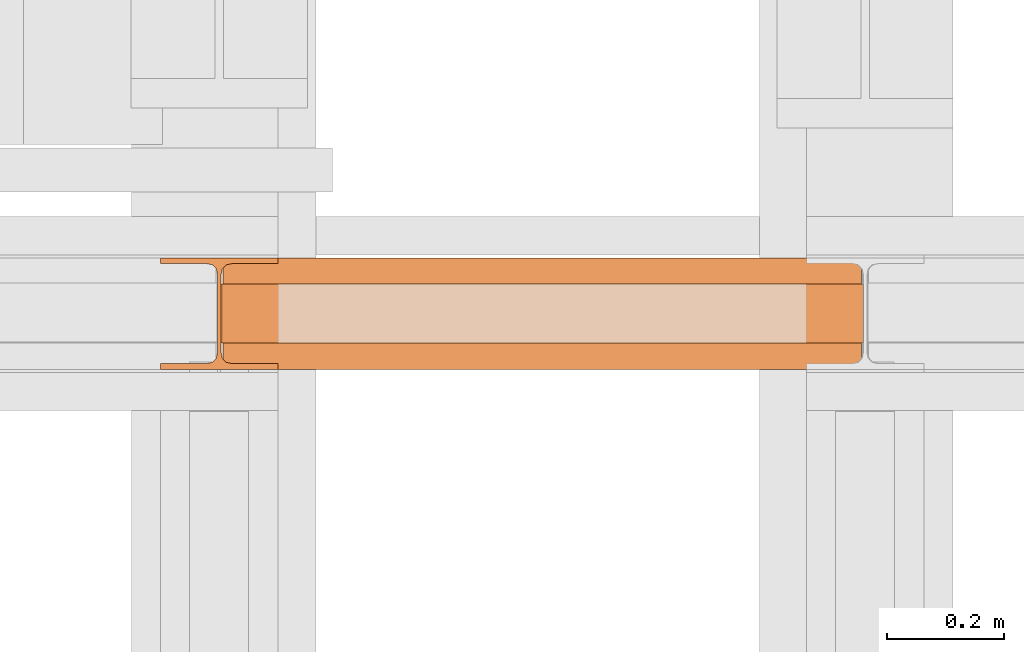
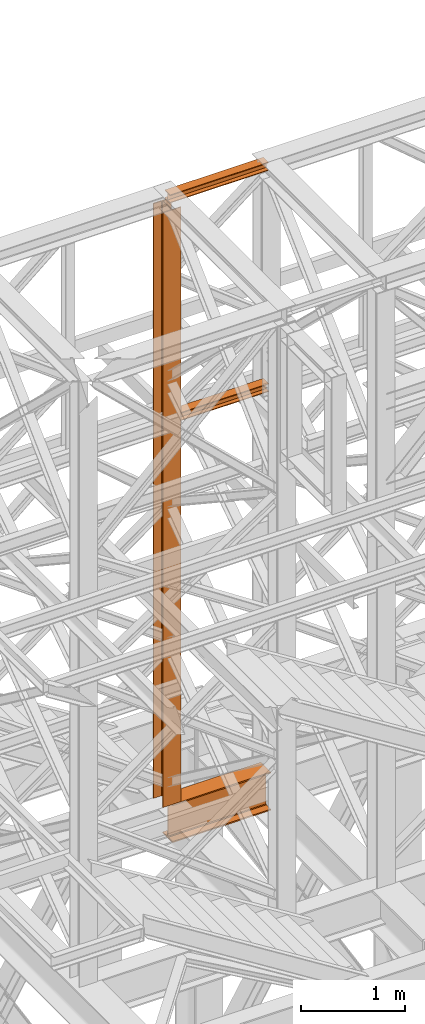
# One storey, part 104 of 208: 4 proxies.
"""IFC2X3 building model written with IfcOpenShell, lengths in millimetres."""

from ifc_helpers import new_model, entity, si_unit, converted_unit, frame, origin, origin_with_axes, place, context, subcontext, project, spatial, faceted_brep, element, save


model = new_model("IFC2X3")

# Units and contexts
model_context = context("Model", 3, precision=1e-05, world=origin())
plan_context = context("Plan", 3, precision=1e-05, world=origin())
body_context = subcontext(model_context, "Body", "Model", "MODEL_VIEW")
ifc_project = project(units=[si_unit("LENGTHUNIT", "METRE", prefix="MILLI"), converted_unit("PLANEANGLEUNIT", "DEGREE", entity("IfcPlaneAngleMeasure", 0.0174532925199433), si_unit("PLANEANGLEUNIT", "RADIAN"), dimensions=[0, 0, 0, 0, 0, 0, 0]), si_unit("AREAUNIT", "SQUARE_METRE"), si_unit("VOLUMEUNIT", "CUBIC_METRE")], contexts=[model_context, plan_context])

# Building, storey
building_placement = place(None, origin())
building = spatial("IfcBuilding", under=ifc_project, at=building_placement, CompositionType="COMPLEX")
storey_placement = place(building_placement, origin_with_axes())
storey = spatial("IfcBuildingStorey", under=building, at=storey_placement, Name="Geschoss", CompositionType="ELEMENT")

# Proxies
proxy_1_placement = place(storey_placement, frame((-1100.745031419179, -13857.57439657637, 4834.989987483023), z_axis=(0.0, 0.0, 1.0), x_axis=(1.0, 0.0, 0.0)))
element("IfcBuildingElementProxy", 1, at=proxy_1_placement, inside=storey, context=body_context, shape_type="Brep", body=[
    faceted_brep([(1088.009999895696, 0.01000000000021828, 450.0100178813937), (1088.009999895696, 190.0100125169756, 450.0100178813937), (1088.009999895696, 190.0100125169756, 435.4100240564349), (1088.009999895696, 120.7100073045494, 435.4100091552737), (1088.009999895696, 109.841562265754, 433.2347078418734), (1088.009999895696, 101.8853126263621, 425.2784563398363), (1088.009999895696, 99.71000619068764, 414.4100113010409), (1088.009999895696, 99.71000619068764, 35.60999167919181), (1088.009999895696, 101.8853126263621, 24.74154664039634), (1088.009999895696, 109.841562265754, 16.78529513835929), (1088.009999895696, 120.7100073045494, 14.60999382495902), (1088.009999895696, 190.0100125169756, 14.60999382495902), (1088.009999895696, 190.0100125169756, 0.01000000000021828), (1088.009999895696, 0.01000000000021828, 0.01000000000021828), (1088.009999895696, 0.01000000000021828, 14.60999382495902), (1088.009999895696, 69.3100052124264, 14.60999382495902), (1088.009999895696, 80.17845025122188, 16.78529513835929), (1088.009999895696, 88.13469989061377, 24.74154664039634), (1088.009999895696, 90.3100063262882, 35.60999167919181), (1088.009999895696, 90.3100063262882, 414.4100113010409), (1088.009999895696, 88.13469989061377, 425.2784563398363), (1088.009999895696, 80.17845025122188, 433.2347078418734), (1088.009999895696, 69.3100052124264, 435.4100091552737), (1088.009999895696, 0.01000000000021828, 435.4100240564349), (1088.009999895696, 190.0100125169756, 450.0100178813937), (1088.009999895696, 0.01000000000021828, 450.0100178813937), (0.009999999999990905, 0.01000000000021828, 450.0100178813937), (0.009999999999990905, 190.0100125169756, 450.0100178813937), (1088.009999895696, 190.0100125169756, 435.4100240564349), (1088.009999895696, 190.0100125169756, 450.0100178813937), (0.009999999999990905, 190.0100125169756, 450.0100178813937), (0.009999999999990905, 190.0100125169756, 435.4100240564349), (1088.009999895696, 120.7100073045494, 435.4100091552737), (1088.009999895696, 190.0100125169756, 435.4100240564349), (0.009999999999990905, 190.0100125169756, 435.4100240564349), (0.009999999999990905, 120.7100073045494, 435.4100091552737), (1088.009999895696, 109.841562265754, 433.2347078418734), (1088.009999895696, 120.7100073045494, 435.4100091552737), (0.009999999999990905, 120.7100073045494, 435.4100091552737), (0.009999999999990905, 109.841562265754, 433.2347078418734), (1088.009999895696, 101.8853126263621, 425.2784563398363), (1088.009999895696, 109.841562265754, 433.2347078418734), (0.009999999999990905, 109.841562265754, 433.2347078418734), (0.009999999999990905, 101.8853126263621, 425.2784563398363), (1088.009999895696, 99.71000619068764, 414.4100113010409), (1088.009999895696, 101.8853126263621, 425.2784563398363), (0.009999999999990905, 101.8853126263621, 425.2784563398363), (0.009999999999990905, 99.71000619068764, 414.4100113010409), (1088.009999895696, 99.71000619068764, 35.60999167919181), (1088.009999895696, 99.71000619068764, 414.4100113010409), (0.009999999999990905, 99.71000619068764, 414.4100113010409), (0.009999999999990905, 99.71000619068764, 35.60999167919181), (1088.009999895696, 101.8853126263621, 24.74154664039634), (1088.009999895696, 99.71000619068764, 35.60999167919181), (0.009999999999990905, 99.71000619068764, 35.60999167919181), (0.009999999999990905, 101.8853126263621, 24.74154664039634), (1088.009999895696, 109.841562265754, 16.78529513835929), (1088.009999895696, 101.8853126263621, 24.74154664039634), (0.009999999999990905, 101.8853126263621, 24.74154664039634), (0.009999999999990905, 109.841562265754, 16.78529513835929), (1088.009999895696, 120.7100073045494, 14.60999382495902), (1088.009999895696, 109.841562265754, 16.78529513835929), (0.009999999999990905, 109.841562265754, 16.78529513835929), (0.009999999999990905, 120.7100073045494, 14.60999382495902), (1088.009999895696, 190.0100125169756, 14.60999382495902), (1088.009999895696, 120.7100073045494, 14.60999382495902), (0.009999999999990905, 120.7100073045494, 14.60999382495902), (0.009999999999990905, 190.0100125169756, 14.60999382495902), (1088.009999895696, 190.0100125169756, 0.01000000000021828), (1088.009999895696, 190.0100125169756, 14.60999382495902), (0.009999999999990905, 190.0100125169756, 14.60999382495902), (0.009999999999990905, 190.0100125169756, 0.01000000000021828), (1088.009999895696, 0.01000000000021828, 0.01000000000021828), (1088.009999895696, 190.0100125169756, 0.01000000000021828), (0.009999999999990905, 190.0100125169756, 0.01000000000021828), (0.009999999999990905, 0.01000000000021828, 0.01000000000021828), (1088.009999895696, 0.01000000000021828, 14.60999382495902), (1088.009999895696, 0.01000000000021828, 0.01000000000021828), (0.009999999999990905, 0.01000000000021828, 0.01000000000021828), (0.009999999999990905, 0.01000000000021828, 14.60999382495902), (1088.009999895696, 69.3100052124264, 14.60999382495902), (1088.009999895696, 0.01000000000021828, 14.60999382495902), (0.009999999999990905, 0.01000000000021828, 14.60999382495902), (0.009999999999990905, 69.3100052124264, 14.60999382495902), (1088.009999895696, 80.17845025122188, 16.78529513835929), (1088.009999895696, 69.3100052124264, 14.60999382495902), (0.009999999999990905, 69.3100052124264, 14.60999382495902), (0.009999999999990905, 80.17845025122188, 16.78529513835929), (1088.009999895696, 88.13469989061377, 24.74154664039634), (1088.009999895696, 80.17845025122188, 16.78529513835929), (0.009999999999990905, 80.17845025122188, 16.78529513835929), (0.009999999999990905, 88.13469989061377, 24.74154664039634), (1088.009999895696, 90.3100063262882, 35.60999167919181), (1088.009999895696, 88.13469989061377, 24.74154664039634), (0.009999999999990905, 88.13469989061377, 24.74154664039634), (0.009999999999990905, 90.3100063262882, 35.60999167919181), (1088.009999895696, 90.3100063262882, 414.4100113010409), (1088.009999895696, 90.3100063262882, 35.60999167919181), (0.009999999999990905, 90.3100063262882, 35.60999167919181), (0.009999999999990905, 90.3100063262882, 414.4100113010409), (1088.009999895696, 88.13469989061377, 425.2784563398363), (1088.009999895696, 90.3100063262882, 414.4100113010409), (0.009999999999990905, 90.3100063262882, 414.4100113010409), (0.009999999999990905, 88.13469989061377, 425.2784563398363), (1088.009999895696, 80.17845025122188, 433.2347078418734), (1088.009999895696, 88.13469989061377, 425.2784563398363), (0.009999999999990905, 88.13469989061377, 425.2784563398363), (0.009999999999990905, 80.17845025122188, 433.2347078418734), (1088.009999895696, 69.3100052124264, 435.4100091552737), (1088.009999895696, 80.17845025122188, 433.2347078418734), (0.009999999999990905, 80.17845025122188, 433.2347078418734), (0.009999999999990905, 69.3100052124264, 435.4100091552737), (1088.009999895696, 0.01000000000021828, 435.4100240564349), (1088.009999895696, 69.3100052124264, 435.4100091552737), (0.009999999999990905, 69.3100052124264, 435.4100091552737), (0.009999999999990905, 0.01000000000021828, 435.4100240564349), (1088.009999895696, 0.01000000000021828, 450.0100178813937), (1088.009999895696, 0.01000000000021828, 435.4100240564349), (0.009999999999990905, 0.01000000000021828, 435.4100240564349), (0.009999999999990905, 0.01000000000021828, 450.0100178813937), (0.009999999999990905, 0.01000000000021828, 450.0100178813937), (0.009999999999990905, 0.01000000000021828, 435.4100240564349), (0.009999999999990905, 69.3100052124264, 435.4100091552737), (0.009999999999990905, 80.17845025122188, 433.2347078418734), (0.009999999999990905, 88.13469989061377, 425.2784563398363), (0.009999999999990905, 90.3100063262882, 414.4100113010409), (0.009999999999990905, 90.3100063262882, 35.60999167919181), (0.009999999999990905, 88.13469989061377, 24.74154664039634), (0.009999999999990905, 80.17845025122188, 16.78529513835929), (0.009999999999990905, 69.3100052124264, 14.60999382495902), (0.009999999999990905, 0.01000000000021828, 14.60999382495902), (0.009999999999990905, 0.01000000000021828, 0.01000000000021828), (0.009999999999990905, 190.0100125169756, 0.01000000000021828), (0.009999999999990905, 190.0100125169756, 14.60999382495902), (0.009999999999990905, 120.7100073045494, 14.60999382495902), (0.009999999999990905, 109.841562265754, 16.78529513835929), (0.009999999999990905, 101.8853126263621, 24.74154664039634), (0.009999999999990905, 99.71000619068764, 35.60999167919181), (0.009999999999990905, 99.71000619068764, 414.4100113010409), (0.009999999999990905, 101.8853126263621, 425.2784563398363), (0.009999999999990905, 109.841562265754, 433.2347078418734), (0.009999999999990905, 120.7100073045494, 435.4100091552737), (0.009999999999990905, 190.0100125169756, 435.4100240564349), (0.009999999999990905, 190.0100125169756, 450.0100178813937)], [[[0, 1, 2, 3, 4, 5, 6, 7, 8, 9, 10, 11, 12, 13, 14, 15, 16, 17, 18, 19, 20, 21, 22, 23]], [[24, 25, 26, 27]], [[28, 29, 30, 31]], [[32, 33, 34, 35]], [[36, 37, 38, 39]], [[40, 41, 42, 43]], [[44, 45, 46, 47]], [[48, 49, 50, 51]], [[52, 53, 54, 55]], [[56, 57, 58, 59]], [[60, 61, 62, 63]], [[64, 65, 66, 67]], [[68, 69, 70, 71]], [[72, 73, 74, 75]], [[76, 77, 78, 79]], [[80, 81, 82, 83]], [[84, 85, 86, 87]], [[88, 89, 90, 91]], [[92, 93, 94, 95]], [[96, 97, 98, 99]], [[100, 101, 102, 103]], [[104, 105, 106, 107]], [[108, 109, 110, 111]], [[112, 113, 114, 115]], [[116, 117, 118, 119]], [[120, 121, 122, 123, 124, 125, 126, 127, 128, 129, 130, 131, 132, 133, 134, 135, 136, 137, 138, 139, 140, 141, 142, 143]]], orient=[[False], [False], [False], [False], [False], [False], [False], [False], [False], [False], [False], [False], [False], [False], [False], [False], [False], [False], [False], [False], [False], [False], [False], [False], [False], [False]]),
])
proxy_2_placement = place(storey_placement, frame((-1206.745032961453, -13857.57439657637, 5284.990005364415), z_axis=(0.0, 0.0, 1.0), x_axis=(1.0, 0.0, 0.0)))
element("IfcBuildingElementProxy", 2, at=proxy_2_placement, inside=storey, context=body_context, shape_type="Brep", body=[
    faceted_brep([(0.009999999999990905, 190.0100125169756, 6965.010053329393), (200.0100029802322, 190.0100125169756, 6965.010053329393), (200.0100029802322, 180.0100146031382, 6965.010053329393), (121.2600035762787, 180.0100071525576, 6965.010053329393), (111.9441915473342, 178.1454621052744, 6965.010053329393), (105.1245498640835, 171.3258190250399, 6965.010053329393), (103.2600015571713, 162.010007927418, 6965.010053329393), (103.2600015571713, 28.00999713897727, 6965.010053329393), (105.1245498640835, 18.69418604135535, 6965.010053329393), (111.9441915473342, 11.87454296112082, 6965.010053329393), (121.2600035762787, 10.00999791383765, 6965.010053329393), (200.0100029802322, 10.00999791383765, 6965.010053329393), (200.0100029802322, 0.01000000000021828, 6965.010053329393), (0.009999999999990905, 0.01000000000021828, 6965.010053329393), (0.009999999999990905, 10.00999791383765, 6965.010053329393), (78.75999940395354, 10.00999791383765, 6965.010053329393), (88.07581143289804, 11.87454296112082, 6965.010053329393), (94.8954531161487, 18.69418604135535, 6965.010053329393), (96.76000142306088, 28.00999713897727, 6965.010053329393), (96.76000142306088, 162.010007927418, 6965.010053329393), (94.8954531161487, 171.3258190250399, 6965.010053329393), (88.07581143289804, 178.1454621052744, 6965.010053329393), (78.75999940395354, 180.0100071525576, 6965.010053329393), (0.009999999999990905, 180.0100146031382, 6965.010053329393), (200.0100029802322, 190.0100125169756, 6965.010053329393), (0.009999999999990905, 190.0100125169756, 6965.010053329393), (0.009999999999990905, 190.0100125169756, 0.01000000000112777), (200.0100029802322, 190.0100125169756, 0.01000000000112777), (200.0100029802322, 180.0100146031382, 6965.010053329393), (200.0100029802322, 190.0100125169756, 6965.010053329393), (200.0100029802322, 190.0100125169756, 0.01000000000112777), (200.0100029802322, 180.0100146031382, 0.01000000000112777), (121.2600035762787, 180.0100071525576, 6965.010053329393), (200.0100029802322, 180.0100146031382, 6965.010053329393), (200.0100029802322, 180.0100146031382, 0.01000000000112777), (121.2600035762787, 180.0100071525576, 0.01000000000112777), (111.9441915473342, 178.1454621052744, 6965.010053329393), (121.2600035762787, 180.0100071525576, 6965.010053329393), (121.2600035762787, 180.0100071525576, 0.01000000000112777), (111.9441915473342, 178.1454621052744, 0.01000000000112777), (105.1245498640835, 171.3258190250399, 6965.010053329393), (111.9441915473342, 178.1454621052744, 6965.010053329393), (111.9441915473342, 178.1454621052744, 0.01000000000112777), (105.1245498640835, 171.3258190250399, 0.01000000000112777), (103.2600015571713, 162.010007927418, 6965.010053329393), (105.1245498640835, 171.3258190250399, 6965.010053329393), (105.1245498640835, 171.3258190250399, 0.01000000000112777), (103.2600015571713, 162.010007927418, 0.01000000000112777), (103.2600015571713, 28.00999713897727, 6965.010053329393), (103.2600015571713, 162.010007927418, 6965.010053329393), (103.2600015571713, 162.010007927418, 0.01000000000112777), (103.2600015571713, 28.00999713897727, 0.01000000000112777), (105.1245498640835, 18.69418604135535, 6965.010053329393), (103.2600015571713, 28.00999713897727, 6965.010053329393), (103.2600015571713, 28.00999713897727, 0.01000000000112777), (105.1245498640835, 18.69418604135535, 0.01000000000112777), (111.9441915473342, 11.87454296112082, 6965.010053329393), (105.1245498640835, 18.69418604135535, 6965.010053329393), (105.1245498640835, 18.69418604135535, 0.01000000000112777), (111.9441915473342, 11.87454296112082, 0.01000000000112777), (121.2600035762787, 10.00999791383765, 6965.010053329393), (111.9441915473342, 11.87454296112082, 6965.010053329393), (111.9441915473342, 11.87454296112082, 0.01000000000112777), (121.2600035762787, 10.00999791383765, 0.01000000000112777), (200.0100029802322, 10.00999791383765, 6965.010053329393), (121.2600035762787, 10.00999791383765, 6965.010053329393), (121.2600035762787, 10.00999791383765, 0.01000000000112777), (200.0100029802322, 10.00999791383765, 0.01000000000112777), (200.0100029802322, 0.01000000000021828, 6965.010053329393), (200.0100029802322, 10.00999791383765, 6965.010053329393), (200.0100029802322, 10.00999791383765, 0.01000000000112777), (200.0100029802322, 0.01000000000021828, 0.01000000000112777), (0.009999999999990905, 0.01000000000021828, 6965.010053329393), (200.0100029802322, 0.01000000000021828, 6965.010053329393), (200.0100029802322, 0.01000000000021828, 0.01000000000112777), (0.009999999999990905, 0.01000000000021828, 0.01000000000112777), (0.009999999999990905, 10.00999791383765, 6965.010053329393), (0.009999999999990905, 0.01000000000021828, 6965.010053329393), (0.009999999999990905, 0.01000000000021828, 0.01000000000112777), (0.009999999999990905, 10.00999791383765, 0.01000000000112777), (78.75999940395354, 10.00999791383765, 6965.010053329393), (0.009999999999990905, 10.00999791383765, 6965.010053329393), (0.009999999999990905, 10.00999791383765, 0.01000000000112777), (78.75999940395354, 10.00999791383765, 0.01000000000112777), (88.07581143289804, 11.87454296112082, 6965.010053329393), (78.75999940395354, 10.00999791383765, 6965.010053329393), (78.75999940395354, 10.00999791383765, 0.01000000000112777), (88.07581143289804, 11.87454296112082, 0.01000000000112777), (94.8954531161487, 18.69418604135535, 6965.010053329393), (88.07581143289804, 11.87454296112082, 6965.010053329393), (88.07581143289804, 11.87454296112082, 0.01000000000112777), (94.8954531161487, 18.69418604135535, 0.01000000000112777), (96.76000142306088, 28.00999713897727, 6965.010053329393), (94.8954531161487, 18.69418604135535, 6965.010053329393), (94.8954531161487, 18.69418604135535, 0.01000000000112777), (96.76000142306088, 28.00999713897727, 0.01000000000112777), (96.76000142306088, 162.010007927418, 6965.010053329393), (96.76000142306088, 28.00999713897727, 6965.010053329393), (96.76000142306088, 28.00999713897727, 0.01000000000112777), (96.76000142306088, 162.010007927418, 0.01000000000112777), (94.8954531161487, 171.3258190250399, 6965.010053329393), (96.76000142306088, 162.010007927418, 6965.010053329393), (96.76000142306088, 162.010007927418, 0.01000000000112777), (94.8954531161487, 171.3258190250399, 0.01000000000112777), (88.07581143289804, 178.1454621052744, 6965.010053329393), (94.8954531161487, 171.3258190250399, 6965.010053329393), (94.8954531161487, 171.3258190250399, 0.01000000000112777), (88.07581143289804, 178.1454621052744, 0.01000000000112777), (78.75999940395354, 180.0100071525576, 6965.010053329393), (88.07581143289804, 178.1454621052744, 6965.010053329393), (88.07581143289804, 178.1454621052744, 0.01000000000112777), (78.75999940395354, 180.0100071525576, 0.01000000000112777), (0.009999999999990905, 180.0100146031382, 6965.010053329393), (78.75999940395354, 180.0100071525576, 6965.010053329393), (78.75999940395354, 180.0100071525576, 0.01000000000112777), (0.009999999999990905, 180.0100146031382, 0.01000000000112777), (0.009999999999990905, 190.0100125169756, 6965.010053329393), (0.009999999999990905, 180.0100146031382, 6965.010053329393), (0.009999999999990905, 180.0100146031382, 0.01000000000112777), (0.009999999999990905, 190.0100125169756, 0.01000000000112777), (0.009999999999990905, 190.0100125169756, 0.01000000000112777), (0.009999999999990905, 180.0100146031382, 0.01000000000112777), (78.75999940395354, 180.0100071525576, 0.01000000000112777), (88.07581143289804, 178.1454621052744, 0.01000000000112777), (94.8954531161487, 171.3258190250399, 0.01000000000112777), (96.76000142306088, 162.010007927418, 0.01000000000112777), (96.76000142306088, 28.00999713897727, 0.01000000000112777), (94.8954531161487, 18.69418604135535, 0.01000000000112777), (88.07581143289804, 11.87454296112082, 0.01000000000112777), (78.75999940395354, 10.00999791383765, 0.01000000000112777), (0.009999999999990905, 10.00999791383765, 0.01000000000112777), (0.009999999999990905, 0.01000000000021828, 0.01000000000112777), (200.0100029802322, 0.01000000000021828, 0.01000000000112777), (200.0100029802322, 10.00999791383765, 0.01000000000112777), (121.2600035762787, 10.00999791383765, 0.01000000000112777), (111.9441915473342, 11.87454296112082, 0.01000000000112777), (105.1245498640835, 18.69418604135535, 0.01000000000112777), (103.2600015571713, 28.00999713897727, 0.01000000000112777), (103.2600015571713, 162.010007927418, 0.01000000000112777), (105.1245498640835, 171.3258190250399, 0.01000000000112777), (111.9441915473342, 178.1454621052744, 0.01000000000112777), (121.2600035762787, 180.0100071525576, 0.01000000000112777), (200.0100029802322, 180.0100146031382, 0.01000000000112777), (200.0100029802322, 190.0100125169756, 0.01000000000112777)], [[[0, 1, 2, 3, 4, 5, 6, 7, 8, 9, 10, 11, 12, 13, 14, 15, 16, 17, 18, 19, 20, 21, 22, 23]], [[24, 25, 26, 27]], [[28, 29, 30, 31]], [[32, 33, 34, 35]], [[36, 37, 38, 39]], [[40, 41, 42, 43]], [[44, 45, 46, 47]], [[48, 49, 50, 51]], [[52, 53, 54, 55]], [[56, 57, 58, 59]], [[60, 61, 62, 63]], [[64, 65, 66, 67]], [[68, 69, 70, 71]], [[72, 73, 74, 75]], [[76, 77, 78, 79]], [[80, 81, 82, 83]], [[84, 85, 86, 87]], [[88, 89, 90, 91]], [[92, 93, 94, 95]], [[96, 97, 98, 99]], [[100, 101, 102, 103]], [[104, 105, 106, 107]], [[108, 109, 110, 111]], [[112, 113, 114, 115]], [[116, 117, 118, 119]], [[120, 121, 122, 123, 124, 125, 126, 127, 128, 129, 130, 131, 132, 133, 134, 135, 136, 137, 138, 139, 140, 141, 142, 143]]], orient=[[False], [False], [False], [False], [False], [False], [False], [False], [False], [False], [False], [False], [False], [False], [False], [False], [False], [False], [False], [False], [False], [False], [False], [False], [False], [False]]),
])
proxy_3_placement = place(storey_placement, frame((-1101.630483097367, -13812.50587051042, 9710.105713222341), z_axis=(0.0, 0.0, 1.0), x_axis=(1.0, 0.0, 0.0)))
element("IfcBuildingElementProxy", 3, at=proxy_3_placement, inside=storey, context=body_context, shape_type="Brep", body=[
    faceted_brep([(1091.936120735611, 0.01000000000021828, 88.01000000000022), (1091.936120735611, 0.01000000000021828, 96.01000000000022), (1091.936120735611, 100.0100000000002, 96.01000000000022), (1091.936120735611, 100.0100000000002, 88.01000000000022), (1091.936120735611, 52.51000000000022, 88.01000000000022), (1091.936120735611, 52.51000000000022, 8.010000000000218), (1091.936120735611, 100.0100000000002, 8.010000000000218), (1091.936120735611, 100.0100000000002, 0.01000000000021828), (1091.936120735611, 0.01000000000021828, 0.01000000000021828), (1091.936120735611, 0.01000000000021828, 8.010000000000218), (1091.936120735611, 47.51000000000022, 8.010000000000218), (1091.936120735611, 47.51000000000022, 88.01000000000022), (1091.936120735611, 0.01000000000021828, 96.01000000000022), (1091.936120735611, 0.01000000000021828, 88.01000000000022), (0.009999999999990905, 0.01000000000385626, 88.01000000000022), (0.009999999999990905, 0.01000000000385626, 96.01000000000022), (1091.936120735611, 100.0100000000002, 96.01000000000022), (1091.936120735611, 0.01000000000021828, 96.01000000000022), (0.009999999999990905, 0.01000000000385626, 96.01000000000022), (0.009999999999990905, 100.0100000000039, 96.01000000000022), (1091.936120735611, 100.0100000000002, 88.01000000000022), (1091.936120735611, 100.0100000000002, 96.01000000000022), (0.009999999999990905, 100.0100000000039, 96.01000000000022), (0.009999999999990905, 100.0100000000039, 88.01000000000022), (1091.936120735611, 52.51000000000022, 88.01000000000022), (1091.936120735611, 100.0100000000002, 88.01000000000022), (0.009999999999990905, 100.0100000000039, 88.01000000000022), (0.009999999999990905, 52.51000000000386, 88.01000000000022), (1091.936120735611, 52.51000000000022, 8.010000000000218), (1091.936120735611, 52.51000000000022, 88.01000000000022), (0.009999999999990905, 52.51000000000386, 88.01000000000022), (0.009999999999990905, 52.51000000000386, 8.010000000000218), (1091.936120735611, 100.0100000000002, 8.010000000000218), (1091.936120735611, 52.51000000000022, 8.010000000000218), (0.009999999999990905, 52.51000000000386, 8.010000000000218), (0.009999999999990905, 100.0100000000039, 8.010000000000218), (1091.936120735611, 100.0100000000002, 0.01000000000021828), (1091.936120735611, 100.0100000000002, 8.010000000000218), (0.009999999999990905, 100.0100000000039, 8.010000000000218), (0.009999999999990905, 100.0100000000039, 0.01000000000021828), (1091.936120735611, 0.01000000000021828, 0.01000000000021828), (1091.936120735611, 100.0100000000002, 0.01000000000021828), (0.009999999999990905, 100.0100000000039, 0.01000000000021828), (0.009999999999990905, 0.01000000000385626, 0.01000000000021828), (1091.936120735611, 0.01000000000021828, 8.010000000000218), (1091.936120735611, 0.01000000000021828, 0.01000000000021828), (0.009999999999990905, 0.01000000000385626, 0.01000000000021828), (0.009999999999990905, 0.01000000000385626, 8.010000000000218), (1091.936120735611, 47.51000000000022, 8.010000000000218), (1091.936120735611, 0.01000000000021828, 8.010000000000218), (0.009999999999990905, 0.01000000000385626, 8.010000000000218), (0.009999999999990905, 47.51000000000386, 8.010000000000218), (1091.936120735611, 47.51000000000022, 88.01000000000022), (1091.936120735611, 47.51000000000022, 8.010000000000218), (0.009999999999990905, 47.51000000000386, 8.010000000000218), (0.009999999999990905, 47.51000000000386, 88.01000000000022), (1091.936120735611, 0.01000000000021828, 88.01000000000022), (1091.936120735611, 47.51000000000022, 88.01000000000022), (0.009999999999990905, 47.51000000000386, 88.01000000000022), (0.009999999999990905, 0.01000000000385626, 88.01000000000022), (0.009999999999990905, 0.01000000000385626, 88.01000000000022), (0.009999999999990905, 47.51000000000386, 88.01000000000022), (0.009999999999990905, 47.51000000000386, 8.010000000000218), (0.009999999999990905, 0.01000000000385626, 8.010000000000218), (0.009999999999990905, 0.01000000000385626, 0.01000000000021828), (0.009999999999990905, 100.0100000000039, 0.01000000000021828), (0.009999999999990905, 100.0100000000039, 8.010000000000218), (0.009999999999990905, 52.51000000000386, 8.010000000000218), (0.009999999999990905, 52.51000000000386, 88.01000000000022), (0.009999999999990905, 100.0100000000039, 88.01000000000022), (0.009999999999990905, 100.0100000000039, 96.01000000000022), (0.009999999999990905, 0.01000000000385626, 96.01000000000022)], [[[0, 1, 2, 3, 4, 5, 6, 7, 8, 9, 10, 11]], [[12, 13, 14, 15]], [[16, 17, 18, 19]], [[20, 21, 22, 23]], [[24, 25, 26, 27]], [[28, 29, 30, 31]], [[32, 33, 34, 35]], [[36, 37, 38, 39]], [[40, 41, 42, 43]], [[44, 45, 46, 47]], [[48, 49, 50, 51]], [[52, 53, 54, 55]], [[56, 57, 58, 59]], [[60, 61, 62, 63, 64, 65, 66, 67, 68, 69, 70, 71]]], orient=[[False], [False], [False], [False], [False], [False], [False], [False], [False], [False], [False], [False], [False], [False]]),
])
proxy_4_placement = place(storey_placement, frame((-1103.495031404279, -13812.50587051042, 12300.47045114381), z_axis=(0.0, 0.0, 1.0), x_axis=(1.0, 0.0, 0.0)))
element("IfcBuildingElementProxy", 4, at=proxy_4_placement, inside=storey, context=body_context, shape_type="Brep", body=[
    faceted_brep([(1093.509999865889, 0.01000000000021828, 88.01000000000022), (1093.509999865889, 0.01000000000021828, 96.01000000000022), (1093.509999865889, 100.0100000000002, 96.01000000000022), (1093.509999865889, 100.0100000000002, 88.01000000000022), (1093.509999865889, 52.51000000000022, 88.01000000000022), (1093.509999865889, 52.51000000000022, 8.010000000000218), (1093.509999865889, 100.0100000000002, 8.010000000000218), (1093.509999865889, 100.0100000000002, 0.01000000000021828), (1093.509999865889, 0.01000000000021828, 0.01000000000021828), (1093.509999865889, 0.01000000000021828, 8.010000000000218), (1093.509999865889, 47.51000000000022, 8.010000000000218), (1093.509999865889, 47.51000000000022, 88.01000000000022), (1093.509999865889, 0.01000000000021828, 96.01000000000022), (1093.509999865889, 0.01000000000021828, 88.01000000000022), (0.009999999999990905, 0.01000000000385626, 88.01000000000022), (0.009999999999990905, 0.01000000000385626, 96.01000000000022), (1093.509999865889, 100.0100000000002, 96.01000000000022), (1093.509999865889, 0.01000000000021828, 96.01000000000022), (0.009999999999990905, 0.01000000000385626, 96.01000000000022), (0.009999999999990905, 100.0100000000039, 96.01000000000022), (1093.509999865889, 100.0100000000002, 88.01000000000022), (1093.509999865889, 100.0100000000002, 96.01000000000022), (0.009999999999990905, 100.0100000000039, 96.01000000000022), (0.009999999999990905, 100.0100000000039, 88.01000000000022), (1093.509999865889, 52.51000000000022, 88.01000000000022), (1093.509999865889, 100.0100000000002, 88.01000000000022), (0.009999999999990905, 100.0100000000039, 88.01000000000022), (0.009999999999990905, 52.51000000000386, 88.01000000000022), (1093.509999865889, 52.51000000000022, 8.010000000000218), (1093.509999865889, 52.51000000000022, 88.01000000000022), (0.009999999999990905, 52.51000000000386, 88.01000000000022), (0.009999999999990905, 52.51000000000386, 8.010000000000218), (1093.509999865889, 100.0100000000002, 8.010000000000218), (1093.509999865889, 52.51000000000022, 8.010000000000218), (0.009999999999990905, 52.51000000000386, 8.010000000000218), (0.009999999999990905, 100.0100000000039, 8.010000000000218), (1093.509999865889, 100.0100000000002, 0.01000000000021828), (1093.509999865889, 100.0100000000002, 8.010000000000218), (0.009999999999990905, 100.0100000000039, 8.010000000000218), (0.009999999999990905, 100.0100000000039, 0.01000000000021828), (1093.509999865889, 0.01000000000021828, 0.01000000000021828), (1093.509999865889, 100.0100000000002, 0.01000000000021828), (0.009999999999990905, 100.0100000000039, 0.01000000000021828), (0.009999999999990905, 0.01000000000385626, 0.01000000000021828), (1093.509999865889, 0.01000000000021828, 8.010000000000218), (1093.509999865889, 0.01000000000021828, 0.01000000000021828), (0.009999999999990905, 0.01000000000385626, 0.01000000000021828), (0.009999999999990905, 0.01000000000385626, 8.010000000000218), (1093.509999865889, 47.51000000000022, 8.010000000000218), (1093.509999865889, 0.01000000000021828, 8.010000000000218), (0.009999999999990905, 0.01000000000385626, 8.010000000000218), (0.009999999999990905, 47.51000000000386, 8.010000000000218), (1093.509999865889, 47.51000000000022, 88.01000000000022), (1093.509999865889, 47.51000000000022, 8.010000000000218), (0.009999999999990905, 47.51000000000386, 8.010000000000218), (0.009999999999990905, 47.51000000000386, 88.01000000000022), (1093.509999865889, 0.01000000000021828, 88.01000000000022), (1093.509999865889, 47.51000000000022, 88.01000000000022), (0.009999999999990905, 47.51000000000386, 88.01000000000022), (0.009999999999990905, 0.01000000000385626, 88.01000000000022), (0.009999999999990905, 0.01000000000385626, 88.01000000000022), (0.009999999999990905, 47.51000000000386, 88.01000000000022), (0.009999999999990905, 47.51000000000386, 8.010000000000218), (0.009999999999990905, 0.01000000000385626, 8.010000000000218), (0.009999999999990905, 0.01000000000385626, 0.01000000000021828), (0.009999999999990905, 100.0100000000039, 0.01000000000021828), (0.009999999999990905, 100.0100000000039, 8.010000000000218), (0.009999999999990905, 52.51000000000386, 8.010000000000218), (0.009999999999990905, 52.51000000000386, 88.01000000000022), (0.009999999999990905, 100.0100000000039, 88.01000000000022), (0.009999999999990905, 100.0100000000039, 96.01000000000022), (0.009999999999990905, 0.01000000000385626, 96.01000000000022)], [[[0, 1, 2, 3, 4, 5, 6, 7, 8, 9, 10, 11]], [[12, 13, 14, 15]], [[16, 17, 18, 19]], [[20, 21, 22, 23]], [[24, 25, 26, 27]], [[28, 29, 30, 31]], [[32, 33, 34, 35]], [[36, 37, 38, 39]], [[40, 41, 42, 43]], [[44, 45, 46, 47]], [[48, 49, 50, 51]], [[52, 53, 54, 55]], [[56, 57, 58, 59]], [[60, 61, 62, 63, 64, 65, 66, 67, 68, 69, 70, 71]]], orient=[[False], [False], [False], [False], [False], [False], [False], [False], [False], [False], [False], [False], [False], [False]]),
])

save(model, "model.ifc")
